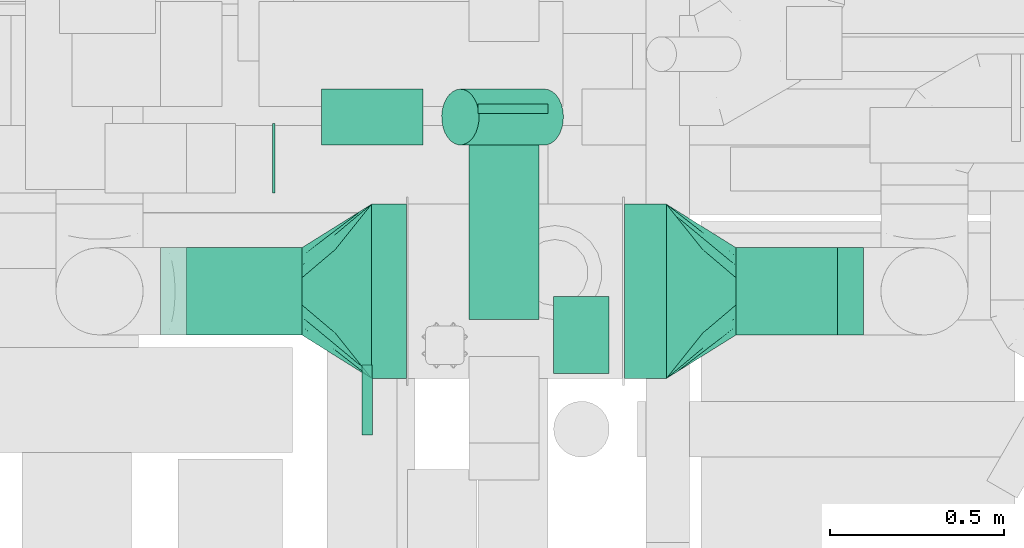
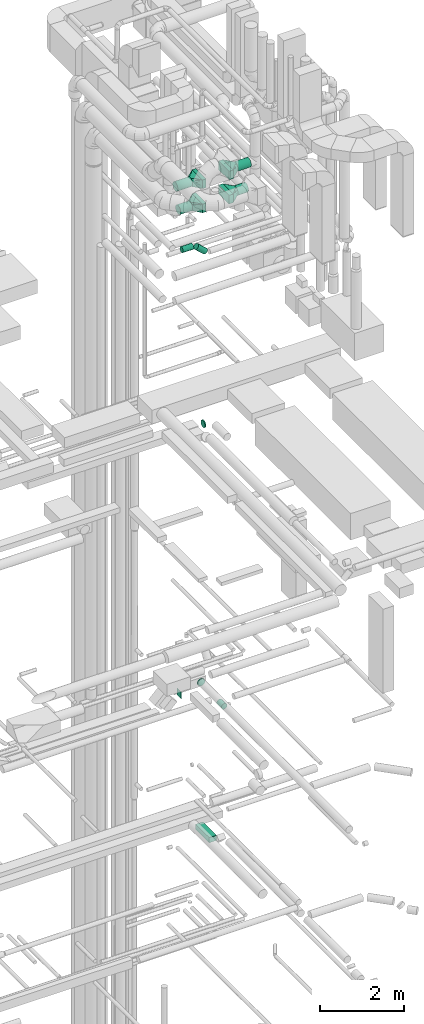
# One storey, part 259 of 337: 14 flow segments, 5 flow fittings.
"""IFC2X3 building model written with IfcOpenShell, lengths in millimetres."""

from ifc_helpers import new_model, entity, si_unit, converted_unit, derived_unit, direction, frame, origin, origin_2d_with_axis, place, context, subcontext, project, spatial, rectangle, circle, extrude, faceted_brep, source, transform, mapped, material, type_object, type_shapes, element, save


model = new_model("IFC2X3")

# Units and contexts
model_context = context("Model", 3, precision=0.01, world=origin(), true_north=direction((6.12303176911189e-17, 1.0)))
body_context = subcontext(model_context, "Body", "Model", "MODEL_VIEW")
ifc_project = project(units=[si_unit("LENGTHUNIT", "METRE", prefix="MILLI"), si_unit("AREAUNIT", "SQUARE_METRE"), si_unit("VOLUMEUNIT", "CUBIC_METRE"), converted_unit("PLANEANGLEUNIT", "DEGREE", entity("IfcRatioMeasure", 0.0174532925199433), si_unit("PLANEANGLEUNIT", "RADIAN"), dimensions=[0, 0, 0, 0, 0, 0, 0]), si_unit("MASSUNIT", "GRAM", prefix="KILO"), derived_unit("MASSDENSITYUNIT", [(si_unit("MASSUNIT", "GRAM", prefix="KILO"), 1), (si_unit("LENGTHUNIT", "METRE"), -3)]), derived_unit("MOMENTOFINERTIAUNIT", [(si_unit("LENGTHUNIT", "METRE"), 4)]), si_unit("TIMEUNIT", "SECOND"), si_unit("FREQUENCYUNIT", "HERTZ"), si_unit("THERMODYNAMICTEMPERATUREUNIT", "DEGREE_CELSIUS"), derived_unit("THERMALTRANSMITTANCEUNIT", [(si_unit("MASSUNIT", "GRAM", prefix="KILO"), 1), (si_unit("THERMODYNAMICTEMPERATUREUNIT", "KELVIN"), -1), (si_unit("TIMEUNIT", "SECOND"), -3)]), derived_unit("VOLUMETRICFLOWRATEUNIT", [(si_unit("LENGTHUNIT", "METRE"), 3), (si_unit("TIMEUNIT", "SECOND"), -1)]), derived_unit("MASSFLOWRATEUNIT", [(si_unit("MASSUNIT", "GRAM", prefix="KILO"), 1), (si_unit("TIMEUNIT", "SECOND"), -1)]), derived_unit("ROTATIONALFREQUENCYUNIT", [(si_unit("TIMEUNIT", "SECOND"), -1)]), si_unit("ELECTRICCURRENTUNIT", "AMPERE"), si_unit("ELECTRICVOLTAGEUNIT", "VOLT"), si_unit("POWERUNIT", "WATT"), si_unit("FORCEUNIT", "NEWTON", prefix="KILO"), si_unit("ILLUMINANCEUNIT", "LUX"), si_unit("LUMINOUSFLUXUNIT", "LUMEN"), si_unit("LUMINOUSINTENSITYUNIT", "CANDELA"), derived_unit("USERDEFINED", [(si_unit("MASSUNIT", "GRAM", prefix="KILO"), -1), (si_unit("LENGTHUNIT", "METRE"), -2), (si_unit("TIMEUNIT", "SECOND"), 3), (si_unit("LUMINOUSFLUXUNIT", "LUMEN"), 1)]), derived_unit("LINEARVELOCITYUNIT", [(si_unit("LENGTHUNIT", "METRE"), 1), (si_unit("TIMEUNIT", "SECOND"), -1)]), si_unit("PRESSUREUNIT", "PASCAL"), derived_unit("USERDEFINED", [(si_unit("LENGTHUNIT", "METRE"), -2), (si_unit("MASSUNIT", "GRAM", prefix="KILO"), 1), (si_unit("TIMEUNIT", "SECOND"), -2)]), derived_unit("LINEARFORCEUNIT", [(si_unit("MASSUNIT", "GRAM", prefix="KILO"), 1), (si_unit("LENGTHUNIT", "METRE"), 1), (si_unit("TIMEUNIT", "SECOND"), -2), (si_unit("LENGTHUNIT", "METRE"), -1)]), derived_unit("PLANARFORCEUNIT", [(si_unit("MASSUNIT", "GRAM", prefix="KILO"), 1), (si_unit("LENGTHUNIT", "METRE"), 1), (si_unit("TIMEUNIT", "SECOND"), -2), (si_unit("LENGTHUNIT", "METRE"), -2)])], contexts=[model_context])

# Site, building, storey
site_placement = place(None, origin())
site = spatial("IfcSite", under=ifc_project, at=site_placement, CompositionType="ELEMENT")
building_placement = place(site_placement, origin())
building = spatial("IfcBuilding", under=site, at=building_placement, CompositionType="ELEMENT")
storey_placement = place(building_placement, origin())
storey = spatial("IfcBuildingStorey", under=building, at=storey_placement, CompositionType="ELEMENT", Elevation=0.0)

# Flow segments
duct_segment_type_1 = type_object("IfcDuctSegmentType", PredefinedType="NOTDEFINED")
flow_segment_1_placement = place(storey_placement, frame((69187.53, 9113.49, 14895.0)))
element("IfcFlowSegment", 1, at=flow_segment_1_placement, inside=storey, type_object=duct_segment_type_1, context=body_context, shape_type="SweptSolid", body=[
    extrude(rectangle(XDim=646.49455206609, YDim=199.999999999998, at=origin_2d_with_axis()), frame((100.0, 323.25, 0.0), z_axis=(0.0, 0.0, 1.0), x_axis=(0.0, -1.0, 0.0)), (0.0, 0.0, 1.0), 150.000000000001),
])
flow_segment_2_placement = place(storey_placement, frame((68624.5, 9475.53, 19050.0)))
element("IfcFlowSegment", 2, at=flow_segment_2_placement, inside=storey, type_object=duct_segment_type_1, context=body_context, shape_type="SweptSolid", body=[
    extrude(rectangle(XDim=6.4466094067617, YDim=200.0, at=origin_2d_with_axis()), frame((3.22, 100.0, 0.0)), (0.0, 0.0, 1.0), 200.000000000002),
])
flow_segment_3_placement = place(storey_placement, frame((69633.1, 8943.7, 33375.0)))
element("IfcFlowSegment", 3, at=flow_segment_3_placement, inside=storey, type_object=duct_segment_type_1, context=body_context, shape_type="SweptSolid", body=[
    extrude(rectangle(XDim=119.999999999895, YDim=500.0, at=origin_2d_with_axis()), frame((60.0, 250.0, 0.0)), (0.0, 0.0, 1.0), 250.000000000004),
])
flow_segment_4_placement = place(storey_placement, frame((68908.1, 8943.7, 33375.0)))
element("IfcFlowSegment", 4, at=flow_segment_4_placement, inside=storey, type_object=duct_segment_type_1, context=body_context, shape_type="SweptSolid", body=[
    extrude(rectangle(XDim=100.000000000003, YDim=500.0, at=origin_2d_with_axis()), frame((50.0, 250.0, 0.0), z_axis=(0.0, 0.0, 1.0), x_axis=(-1.0, 0.0, 0.0)), (0.0, 0.0, 1.0), 250.000000000004),
])
flow_segment_5_placement = place(storey_placement, frame((69633.1, 8943.7, 34075.0)))
element("IfcFlowSegment", 5, at=flow_segment_5_placement, inside=storey, type_object=duct_segment_type_1, context=body_context, shape_type="SweptSolid", body=[
    extrude(rectangle(XDim=119.99999999999, YDim=500.0, at=origin_2d_with_axis()), frame((60.0, 250.0, 0.0)), (0.0, 0.0, 1.0), 250.000000000004),
])
flow_segment_6_placement = place(storey_placement, frame((68908.1, 8943.7, 34075.0)))
element("IfcFlowSegment", 6, at=flow_segment_6_placement, inside=storey, type_object=duct_segment_type_1, context=body_context, shape_type="SweptSolid", body=[
    extrude(rectangle(XDim=100.000000000012, YDim=500.0, at=origin_2d_with_axis()), frame((50.0, 250.0, 0.0), z_axis=(0.0, 0.0, 1.0), x_axis=(-1.0, 0.0, 0.0)), (0.0, 0.0, 1.0), 250.000000000004),
])
duct_segment_type_2 = type_object("IfcDuctSegmentType", PredefinedType="NOTDEFINED")
flow_segment_7_placement = place(storey_placement, frame((69428.24, 8958.57, 18753.4)))
element("IfcFlowSegment", 7, at=flow_segment_7_placement, inside=storey, type_object=duct_segment_type_2, context=body_context, shape_type="SweptSolid", body=[
    extrude(circle(Radius=80.0, at=origin_2d_with_axis()), frame((81.6, 0.0, 81.6), z_axis=(0.0, 1.0, 0.0), x_axis=(-1.0, 0.0, 0.0)), (0.0, 0.0, 1.0), 220.000000000024),
])
flow_segment_8_placement = place(storey_placement, frame((68378.1, 9067.1, 33373.4)))
element("IfcFlowSegment", 8, at=flow_segment_8_placement, inside=storey, type_object=duct_segment_type_2, context=body_context, shape_type="SweptSolid", body=[
    extrude(circle(Radius=125.0, at=origin_2d_with_axis()), frame((0.0, 126.6, 126.6), z_axis=(1.0, 0.0, 0.0), x_axis=(0.0, 1.0, 0.0)), (0.0, 0.0, 1.0), 329.999999999977),
])
flow_segment_9_placement = place(storey_placement, frame((69953.1, 9067.1, 34073.4)))
element("IfcFlowSegment", 9, at=flow_segment_9_placement, inside=storey, type_object=duct_segment_type_2, context=body_context, shape_type="SweptSolid", body=[
    extrude(circle(Radius=125.0, at=origin_2d_with_axis()), frame((0.0, 126.6, 126.6), z_axis=(1.0, 0.0, 0.0), x_axis=(0.0, -1.0, 0.0)), (0.0, 0.0, 1.0), 364.999999999995),
])
flow_segment_10_placement = place(storey_placement, frame((68303.1, 9067.1, 34073.4)))
element("IfcFlowSegment", 10, at=flow_segment_10_placement, inside=storey, type_object=duct_segment_type_2, context=body_context, shape_type="SweptSolid", body=[
    extrude(circle(Radius=125.0, at=origin_2d_with_axis()), frame((0.0, 126.6, 126.6), z_axis=(1.0, 0.0, 0.0), x_axis=(0.0, 1.0, 0.0)), (0.0, 0.0, 1.0), 404.999999999977),
])
flow_segment_11_placement = place(storey_placement, frame((69107.44, 9611.82, 31580.05)))
element("IfcFlowSegment", 11, at=flow_segment_11_placement, inside=storey, type_object=duct_segment_type_2, context=body_context, shape_type="SweptSolid", body=[
    extrude(circle(Radius=80.0, at=origin_2d_with_axis()), frame((297.02, 81.6, 61.05), z_axis=(-0.743144825477395, 0.0, 0.669130606358858), x_axis=(0.0, 1.0, 0.0)), (0.0, 0.0, 1.0), 325.506473748016),
])
flow_segment_12_placement = place(storey_placement, frame((68764.23, 9611.82, 31818.4)))
element("IfcFlowSegment", 12, at=flow_segment_12_placement, inside=storey, type_object=duct_segment_type_2, context=body_context, shape_type="SweptSolid", body=[
    extrude(circle(Radius=80.0, at=origin_2d_with_axis()), frame((0.0, 81.6, 81.6), z_axis=(1.0, 0.0, 0.0), x_axis=(0.0, 1.0, 0.0)), (0.0, 0.0, 1.0), 291.276049524378),
])
flow_segment_13_placement = place(storey_placement, frame((68880.62, 8780.81, 27198.4)))
element("IfcFlowSegment", 13, at=flow_segment_13_placement, inside=storey, type_object=duct_segment_type_2, context=body_context, shape_type="SweptSolid", body=[
    extrude(circle(Radius=100.0, at=origin_2d_with_axis()), frame((0.0, 101.6, 101.6), z_axis=(1.0, 0.0, 0.0), x_axis=(0.0, -1.0, 0.0)), (0.0, 0.0, 1.0), 29.895200000035),
])
flow_segment_14_placement = place(storey_placement, frame((69953.1, 9067.1, 33373.4)))
element("IfcFlowSegment", 14, at=flow_segment_14_placement, inside=storey, type_object=duct_segment_type_2, context=body_context, shape_type="SweptSolid", body=[
    extrude(circle(Radius=125.0, at=origin_2d_with_axis()), frame((0.0, 126.6, 126.6), z_axis=(1.0, 0.0, 0.0), x_axis=(0.0, -1.0, 0.0)), (0.0, 0.0, 1.0), 290.000000000107),
])

# Flow fittings
ifc_material = material()
duct_fitting_type_1 = type_object("IfcDuctFittingType", PredefinedType="NOTDEFINED", material=ifc_material)
shared_shape_1 = source(origin(), body_context, "Body", "Brep", [
    faceted_brep([(20.0, 0.0, -100.0), (20.0, 25.88, -96.59), (20.0, 50.0, -86.6), (20.0, 70.71, -70.71), (20.0, 86.6, -50.0), (20.0, 96.59, -25.88), (20.0, 100.0, 0.0), (20.0, 96.59, 25.88), (20.0, 86.6, 50.0), (20.0, 70.71, 70.71), (20.0, 50.0, 86.6), (20.0, 25.88, 96.59), (20.0, 0.0, 100.0), (20.0, -25.88, 96.59), (20.0, -50.0, 86.6), (20.0, -70.71, 70.71), (20.0, -86.6, 50.0), (20.0, -96.59, 25.88), (20.0, -100.0, 0.0), (20.0, -96.59, -25.88), (20.0, -86.6, -50.0), (20.0, -70.71, -70.71), (20.0, -50.0, -86.6), (20.0, -25.88, -96.59), (0.0, 0.0, 100.0), (-6.1, 0.0, 100.0), (-6.1, -25.88, 96.59), (0.0, -25.88, 96.59), (-6.1, -50.0, 86.6), (0.0, -50.0, 86.6), (0.0, -70.71, 70.71), (-6.1, -70.71, 70.71), (0.0, -86.6, 50.0), (-6.1, -86.6, 50.0), (-6.1, -96.59, 25.88), (0.0, -96.59, 25.88), (-6.1, -100.0, 0.0), (0.0, -100.0, 0.0), (-6.1, -96.59, -25.88), (0.0, -96.59, -25.88), (-6.1, -86.6, -50.0), (0.0, -86.6, -50.0), (0.0, -70.71, -70.71), (-6.1, -70.71, -70.71), (0.0, -50.0, -86.6), (-6.1, -50.0, -86.6), (-6.1, -25.88, -96.59), (0.0, -25.88, -96.59), (-6.1, 0.0, -100.0), (0.0, 0.0, -100.0), (-6.1, 25.88, -96.59), (0.0, 25.88, -96.59), (-6.1, 50.0, -86.6), (0.0, 50.0, -86.6), (0.0, 70.71, -70.71), (-6.1, 70.71, -70.71), (0.0, 86.6, -50.0), (-6.1, 86.6, -50.0), (-6.1, 96.59, -25.88), (0.0, 96.59, -25.88), (-6.1, 100.0, 0.0), (0.0, 100.0, 0.0), (-6.1, 96.59, 25.88), (0.0, 96.59, 25.88), (-6.1, 86.6, 50.0), (0.0, 86.6, 50.0), (0.0, 70.71, 70.71), (-6.1, 70.71, 70.71), (0.0, 50.0, 86.6), (-6.1, 50.0, 86.6), (-6.1, 25.88, 96.59), (0.0, 25.88, 96.59)], [[[0, 1, 2, 3, 4, 5, 6, 7, 8, 9, 10, 11, 12, 13, 14, 15, 16, 17, 18, 19, 20, 21, 22, 23]], [[13, 12, 24, 25, 26, 27]], [[14, 13, 27, 26, 28, 29]], [[30, 15, 14, 29, 28, 31]], [[17, 16, 32, 33, 34, 35]], [[18, 17, 35, 34, 36, 37]], [[32, 16, 15, 30, 31, 33]], [[19, 18, 37, 36, 38, 39]], [[20, 19, 39, 38, 40, 41]], [[42, 21, 20, 41, 40, 43]], [[23, 22, 44, 45, 46, 47]], [[0, 23, 47, 46, 48, 49]], [[44, 22, 21, 42, 43, 45]], [[1, 0, 49, 48, 50, 51]], [[2, 1, 51, 50, 52, 53]], [[54, 3, 2, 53, 52, 55]], [[5, 4, 56, 57, 58, 59]], [[6, 5, 59, 58, 60, 61]], [[56, 4, 3, 54, 55, 57]], [[7, 6, 61, 60, 62, 63]], [[8, 7, 63, 62, 64, 65]], [[66, 9, 8, 65, 64, 67]], [[11, 10, 68, 69, 70, 71]], [[12, 11, 71, 70, 25, 24]], [[68, 10, 9, 66, 67, 69]], [[46, 45, 43, 40, 38, 36, 34, 33, 31, 28, 26, 25, 70, 69, 67, 64, 62, 60, 58, 57, 55, 52, 50, 48]]]),
])
type_shapes(duct_fitting_type_1, [shared_shape_1])
flow_fitting_1_placement = place(storey_placement, frame((69313.79, 9724.07, 19150.0), z_axis=(0.0, 0.0, -1.0), x_axis=(0.0, -1.0, 0.0)))
element("IfcFlowFitting", 15, at=flow_fitting_1_placement, inside=storey, type_object=duct_fitting_type_1, material=ifc_material, context=body_context, shape_type="MappedRepresentation", body=[
    mapped(shared_shape_1, transform((0.0, 0.0, 0.0), scale=1.0)),
])
duct_fitting_type_2 = type_object("IfcDuctFittingType", PredefinedType="NOTDEFINED", material=ifc_material)
shared_shape_2 = source(origin(), body_context, "Body", "Brep", [
    faceted_brep([(200.0, 73.47, 101.13), (200.0, 56.05, 110.0), (200.0, 38.63, 118.88), (200.0, 23.84, 121.22), (200.0, 11.92, 123.11), (200.0, 5.96, 124.06), (200.0, 0.0, 125.0), (200.0, -5.96, 124.06), (200.0, -11.92, 123.11), (200.0, -23.84, 121.22), (200.0, -38.63, 118.88), (200.0, -56.05, 110.0), (200.0, -73.47, 101.13), (200.0, -87.3, 87.3), (200.0, -101.13, 73.47), (200.0, -110.0, 56.05), (200.0, -118.88, 38.63), (200.0, -121.22, 23.84), (200.0, -123.11, 11.92), (200.0, -124.06, 5.96), (200.0, -125.0, 0.0), (200.0, -124.06, -5.96), (200.0, -123.11, -11.92), (200.0, -121.22, -23.84), (200.0, -118.88, -38.63), (200.0, -110.0, -56.05), (200.0, -101.13, -73.47), (200.0, -87.3, -87.3), (200.0, -73.47, -101.13), (200.0, -56.05, -110.0), (200.0, -38.63, -118.88), (200.0, -23.84, -121.22), (200.0, -11.92, -123.11), (200.0, -5.96, -124.06), (200.0, 0.0, -125.0), (200.0, 5.96, -124.06), (200.0, 11.92, -123.11), (200.0, 23.84, -121.22), (200.0, 38.63, -118.88), (200.0, 56.05, -110.0), (200.0, 73.47, -101.13), (200.0, 87.3, -87.3), (200.0, 101.13, -73.47), (200.0, 110.0, -56.05), (200.0, 118.88, -38.63), (200.0, 121.22, -23.84), (200.0, 123.11, -11.92), (200.0, 124.06, -5.96), (200.0, 125.0, 0.0), (200.0, 124.06, 5.96), (200.0, 123.11, 11.92), (200.0, 121.22, 23.84), (200.0, 118.88, 38.63), (200.0, 110.0, 56.05), (200.0, 101.13, 73.47), (200.0, 87.3, 87.3), (0.0, -250.0, 125.0), (0.0, 250.0, 125.0), (0.0, 250.0, -125.0), (0.0, -250.0, -125.0), (104.11, -119.86, 125.0), (100.0, -166.44, 109.29), (26.03, -217.46, 125.0), (78.09, -152.39, 125.0), (52.06, -184.93, 125.0), (188.01, -14.98, 125.0), (176.03, -29.96, 125.0), (152.06, -59.93, 125.0), (128.09, -89.89, 125.0), (52.06, -217.46, 92.46), (78.09, -201.2, 76.2), (104.11, -184.93, 59.93), (128.09, -169.95, 44.95), (152.06, -154.96, 29.96), (176.03, -139.98, 14.98), (188.01, -132.49, 7.49), (26.03, -233.73, 108.73), (26.03, -233.73, -108.73), (52.06, -217.46, -92.46), (78.09, -201.2, -76.2), (104.11, -184.93, -59.93), (128.09, -169.95, -44.95), (152.06, -154.96, -29.96), (176.03, -139.98, -14.98), (188.01, -132.49, -7.49), (100.0, -171.79, -103.94), (52.06, -184.93, -125.0), (78.09, -152.39, -125.0), (104.11, -119.86, -125.0), (128.09, -89.89, -125.0), (152.06, -59.93, -125.0), (176.03, -29.96, -125.0), (188.01, -14.98, -125.0), (26.03, -217.46, -125.0), (26.03, 217.46, -125.0), (52.06, 184.93, -125.0), (78.09, 152.39, -125.0), (104.11, 119.86, -125.0), (128.09, 89.89, -125.0), (152.06, 59.93, -125.0), (176.03, 29.96, -125.0), (188.01, 14.98, -125.0), (100.0, 166.44, -109.29), (52.06, 217.46, -92.46), (78.09, 201.2, -76.2), (104.11, 184.93, -59.93), (128.09, 169.95, -44.95), (152.06, 154.96, -29.96), (176.03, 139.98, -14.98), (188.01, 132.49, -7.49), (26.03, 233.73, -108.73), (26.03, 233.73, 108.73), (52.06, 217.46, 92.46), (78.09, 201.2, 76.2), (104.11, 184.93, 59.93), (128.09, 169.95, 44.95), (152.06, 154.96, 29.96), (176.03, 139.98, 14.98), (188.01, 132.49, 7.49), (100.0, 171.79, 103.94), (52.06, 184.93, 125.0), (78.09, 152.39, 125.0), (104.11, 119.86, 125.0), (128.09, 89.89, 125.0), (152.06, 59.93, 125.0), (176.03, 29.96, 125.0), (188.01, 14.98, 125.0), (26.03, 217.46, 125.0)], [[[0, 1, 2, 3, 4, 5, 6, 7, 8, 9, 10, 11, 12, 13, 14, 15, 16, 17, 18, 19, 20, 21, 22, 23, 24, 25, 26, 27, 28, 29, 30, 31, 32, 33, 34, 35, 36, 37, 38, 39, 40, 41, 42, 43, 44, 45, 46, 47, 48, 49, 50, 51, 52, 53, 54, 55]], [[56, 57, 58, 59]], [[60, 11, 10]], [[56, 61, 62]], [[11, 60, 63, 64]], [[65, 66, 67, 68, 60, 10, 9, 8, 7, 6]], [[62, 61, 12]], [[15, 69, 70, 71]], [[64, 12, 11]], [[16, 71, 72, 73, 74, 75, 20, 19, 18, 17]], [[14, 76, 69]], [[71, 16, 15]], [[61, 76, 13]], [[12, 64, 62]], [[76, 14, 13]], [[12, 61, 13]], [[61, 56, 76]], [[69, 15, 14]], [[75, 74, 73, 72, 71, 70, 69, 76, 56, 59, 77, 78, 79, 80, 81, 82, 83, 84, 20]], [[80, 25, 24]], [[59, 85, 77]], [[25, 80, 79, 78]], [[84, 83, 82, 81, 80, 24, 23, 22, 21, 20]], [[77, 85, 26]], [[29, 86, 87, 88]], [[78, 26, 25]], [[30, 88, 89, 90, 91, 92, 34, 33, 32, 31]], [[28, 93, 86]], [[88, 30, 29]], [[85, 93, 27]], [[26, 78, 77]], [[93, 28, 27]], [[26, 85, 27]], [[85, 59, 93]], [[86, 29, 28]], [[92, 91, 90, 89, 88, 87, 86, 93, 59, 58, 94, 95, 96, 97, 98, 99, 100, 101, 34]], [[97, 39, 38]], [[58, 102, 94]], [[39, 97, 96, 95]], [[101, 100, 99, 98, 97, 38, 37, 36, 35, 34]], [[94, 102, 40]], [[43, 103, 104, 105]], [[95, 40, 39]], [[44, 105, 106, 107, 108, 109, 48, 47, 46, 45]], [[42, 110, 103]], [[105, 44, 43]], [[102, 110, 41]], [[40, 95, 94]], [[110, 42, 41]], [[40, 102, 41]], [[102, 58, 110]], [[103, 43, 42]], [[58, 57, 111, 112, 113, 114, 115, 116, 117, 118, 48, 109, 108, 107, 106, 105, 104, 103, 110]], [[114, 53, 52]], [[57, 119, 111]], [[53, 114, 113, 112]], [[118, 117, 116, 115, 114, 52, 51, 50, 49, 48]], [[111, 119, 54]], [[1, 120, 121, 122]], [[112, 54, 53]], [[2, 122, 123, 124, 125, 126, 6, 5, 4, 3]], [[0, 127, 120]], [[122, 2, 1]], [[119, 127, 55]], [[54, 112, 111]], [[127, 0, 55]], [[54, 119, 55]], [[119, 57, 127]], [[120, 1, 0]], [[57, 56, 62, 64, 63, 60, 68, 67, 66, 65, 6, 126, 125, 124, 123, 122, 121, 120, 127]]]),
])
type_shapes(duct_fitting_type_2, [shared_shape_2])
flow_fitting_2_placement = place(storey_placement, frame((69753.1, 9193.7, 33500.0)))
element("IfcFlowFitting", 16, at=flow_fitting_2_placement, inside=storey, type_object=duct_fitting_type_2, material=ifc_material, context=body_context, shape_type="MappedRepresentation", body=[
    mapped(shared_shape_2, transform((0.0, 0.0, 0.0), scale=1.0)),
])
flow_fitting_3_placement = place(storey_placement, frame((68908.1, 9193.7, 33500.0), z_axis=(0.0, 0.0, 1.0), x_axis=(-1.0, 0.0, 0.0)))
element("IfcFlowFitting", 17, at=flow_fitting_3_placement, inside=storey, type_object=duct_fitting_type_2, material=ifc_material, context=body_context, shape_type="MappedRepresentation", body=[
    mapped(shared_shape_2, transform((0.0, 0.0, 0.0), scale=1.0)),
])
flow_fitting_4_placement = place(storey_placement, frame((69753.1, 9193.7, 34200.0)))
element("IfcFlowFitting", 18, at=flow_fitting_4_placement, inside=storey, type_object=duct_fitting_type_2, material=ifc_material, context=body_context, shape_type="MappedRepresentation", body=[
    mapped(shared_shape_2, transform((0.0, 0.0, 0.0), scale=1.0)),
])
flow_fitting_5_placement = place(storey_placement, frame((68908.1, 9193.7, 34200.0), z_axis=(0.0, 0.0, 1.0), x_axis=(-1.0, 0.0, 0.0)))
element("IfcFlowFitting", 19, at=flow_fitting_5_placement, inside=storey, type_object=duct_fitting_type_2, material=ifc_material, context=body_context, shape_type="MappedRepresentation", body=[
    mapped(shared_shape_2, transform((0.0, 0.0, 0.0), scale=1.0)),
])

save(model, "model.ifc")
